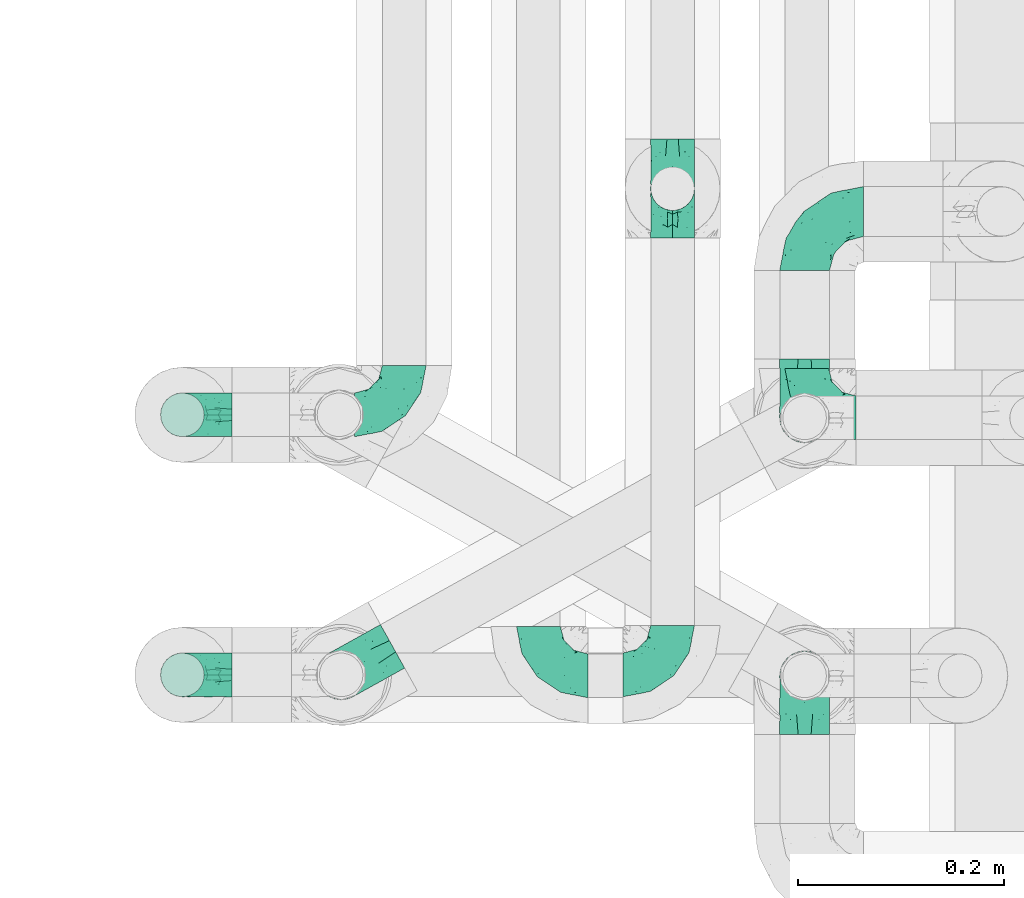
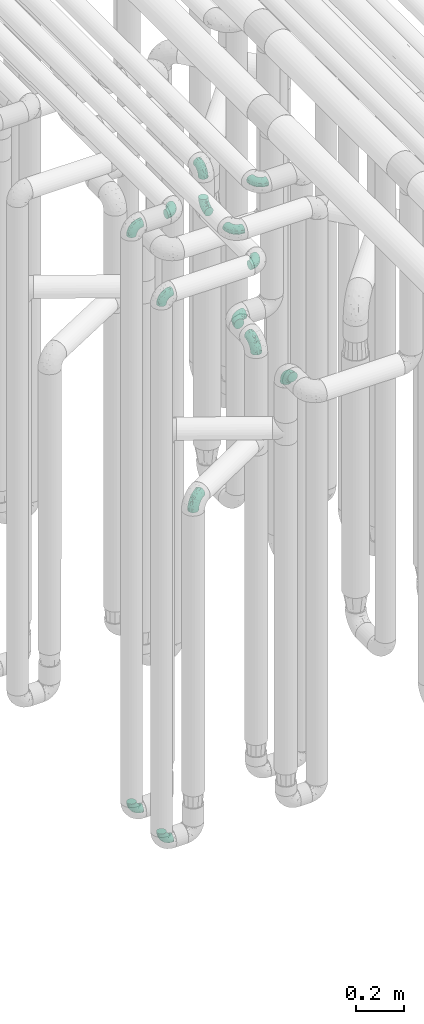
# One storey, part 598 of 827: 14 flow fittings.
"""IFC2X3 building model written with IfcOpenShell, lengths in millimetres."""

from ifc_helpers import new_model, entity, si_unit, converted_unit, derived_unit, direction, frame, origin, place, context, subcontext, project, spatial, faceted_brep, source, transform, mapped, material, type_object, type_shapes, element, save


model = new_model("IFC2X3")

# Units and contexts
model_context = context("Model", 3, precision=0.01, world=origin(), true_north=direction((6.12303176911189e-17, 1.0)))
body_context = subcontext(model_context, "Body", "Model", "MODEL_VIEW")
ifc_project = project(units=[si_unit("LENGTHUNIT", "METRE", prefix="MILLI"), si_unit("AREAUNIT", "SQUARE_METRE"), si_unit("VOLUMEUNIT", "CUBIC_METRE"), converted_unit("PLANEANGLEUNIT", "DEGREE", entity("IfcRatioMeasure", 0.0174532925199433), si_unit("PLANEANGLEUNIT", "RADIAN"), dimensions=[0, 0, 0, 0, 0, 0, 0]), si_unit("MASSUNIT", "GRAM", prefix="KILO"), derived_unit("MASSDENSITYUNIT", [(si_unit("MASSUNIT", "GRAM", prefix="KILO"), 1), (si_unit("LENGTHUNIT", "METRE"), -3)]), derived_unit("MOMENTOFINERTIAUNIT", [(si_unit("LENGTHUNIT", "METRE"), 4)]), si_unit("TIMEUNIT", "SECOND"), si_unit("FREQUENCYUNIT", "HERTZ"), si_unit("THERMODYNAMICTEMPERATUREUNIT", "DEGREE_CELSIUS"), derived_unit("THERMALTRANSMITTANCEUNIT", [(si_unit("MASSUNIT", "GRAM", prefix="KILO"), 1), (si_unit("THERMODYNAMICTEMPERATUREUNIT", "KELVIN"), -1), (si_unit("TIMEUNIT", "SECOND"), -3)]), derived_unit("VOLUMETRICFLOWRATEUNIT", [(si_unit("LENGTHUNIT", "METRE"), 3), (si_unit("TIMEUNIT", "SECOND"), -1)]), derived_unit("MASSFLOWRATEUNIT", [(si_unit("MASSUNIT", "GRAM", prefix="KILO"), 1), (si_unit("TIMEUNIT", "SECOND"), -1)]), derived_unit("ROTATIONALFREQUENCYUNIT", [(si_unit("TIMEUNIT", "SECOND"), -1)]), si_unit("ELECTRICCURRENTUNIT", "AMPERE"), si_unit("ELECTRICVOLTAGEUNIT", "VOLT"), si_unit("POWERUNIT", "WATT"), si_unit("FORCEUNIT", "NEWTON", prefix="KILO"), si_unit("ILLUMINANCEUNIT", "LUX"), si_unit("LUMINOUSFLUXUNIT", "LUMEN"), si_unit("LUMINOUSINTENSITYUNIT", "CANDELA"), derived_unit("USERDEFINED", [(si_unit("MASSUNIT", "GRAM", prefix="KILO"), -1), (si_unit("LENGTHUNIT", "METRE"), -2), (si_unit("TIMEUNIT", "SECOND"), 3), (si_unit("LUMINOUSFLUXUNIT", "LUMEN"), 1)]), derived_unit("LINEARVELOCITYUNIT", [(si_unit("LENGTHUNIT", "METRE"), 1), (si_unit("TIMEUNIT", "SECOND"), -1)]), si_unit("PRESSUREUNIT", "PASCAL"), derived_unit("USERDEFINED", [(si_unit("LENGTHUNIT", "METRE"), -2), (si_unit("MASSUNIT", "GRAM", prefix="KILO"), 1), (si_unit("TIMEUNIT", "SECOND"), -2)]), derived_unit("LINEARFORCEUNIT", [(si_unit("MASSUNIT", "GRAM", prefix="KILO"), 1), (si_unit("LENGTHUNIT", "METRE"), 1), (si_unit("TIMEUNIT", "SECOND"), -2), (si_unit("LENGTHUNIT", "METRE"), -1)]), derived_unit("PLANARFORCEUNIT", [(si_unit("MASSUNIT", "GRAM", prefix="KILO"), 1), (si_unit("LENGTHUNIT", "METRE"), 1), (si_unit("TIMEUNIT", "SECOND"), -2), (si_unit("LENGTHUNIT", "METRE"), -2)])], contexts=[model_context])

# Site, building, storey
site_placement = place(None, origin())
site = spatial("IfcSite", under=ifc_project, at=site_placement, CompositionType="ELEMENT")
building_placement = place(site_placement, origin())
building = spatial("IfcBuilding", under=site, at=building_placement, CompositionType="ELEMENT")
storey_placement = place(building_placement, frame((0.0, 0.0, 28200.0)))
storey = spatial("IfcBuildingStorey", under=building, at=storey_placement, Name="08", CompositionType="ELEMENT", Elevation=28200.0)

# Flow fittings
ifc_material = material()
pipe_fitting_type_1 = type_object("IfcPipeFittingType", Name="ADSK_1", PredefinedType="NOTDEFINED", material=ifc_material)
shared_shape_1 = source(origin(), body_context, "Body", "Brep", [
    faceted_brep([(-57.0, 12.07, -20.91), (-57.0, 6.25, -23.33), (-57.0, 0.0, -24.15), (-57.0, -6.25, -23.33), (-57.0, -12.08, -20.91), (-57.0, -17.08, -17.08), (-57.0, -20.91, -12.08), (-57.0, -23.33, -6.25), (-57.0, -24.15, 0.0), (-57.0, -23.33, 6.25), (-57.0, -20.91, 12.07), (-57.0, -17.08, 17.08), (-57.0, -12.08, 20.91), (-57.0, -6.25, 23.33), (-57.0, 0.0, 24.15), (-57.0, 6.25, 23.33), (-57.0, 12.07, 20.91), (-57.0, 17.08, 17.08), (-57.0, 20.91, 12.07), (-57.0, 23.33, 6.25), (-57.0, 24.15, 0.0), (-57.0, 23.33, -6.25), (-57.0, 20.91, -12.08), (-57.0, 17.08, -17.08), (0.0, 57.0, -24.15), (-6.25, 57.0, -23.33), (-12.07, 57.0, -20.91), (-17.08, 57.0, -17.08), (-20.91, 57.0, -12.08), (-23.33, 57.0, -6.25), (-24.15, 57.0, 0.0), (-23.33, 57.0, 6.25), (-20.91, 57.0, 12.07), (-17.08, 57.0, 17.08), (-12.07, 57.0, 20.91), (-6.25, 57.0, 23.33), (0.0, 57.0, 24.15), (6.25, 57.0, 23.33), (12.08, 57.0, 20.91), (17.08, 57.0, 17.08), (20.91, 57.0, 12.07), (23.33, 57.0, 6.25), (24.15, 57.0, 0.0), (23.33, 57.0, -6.25), (20.91, 57.0, -12.08), (17.08, 57.0, -17.08), (12.08, 57.0, -20.91), (6.25, 57.0, -23.33), (14.9, 21.14, 6.17), (13.61, 24.64, 12.48), (6.23, 8.95, 8.98), (-41.47, -21.06, 0.0), (-41.92, -18.38, 13.72), (-24.64, -13.61, 12.48), (-37.37, -13.24, 18.15), (-6.8, -4.93, 8.18), (-21.76, -15.19, 6.22), (-12.78, -9.18, 0.0), (-37.73, -20.51, 7.75), (-7.38, 7.38, 20.24), (-23.37, -4.26, 20.42), (-11.9, -3.19, 15.86), (-42.14, -8.7, 21.82), (13.24, 37.37, 18.15), (9.33, 23.53, 16.85), (4.26, 23.37, 20.42), (2.77, 10.92, 15.55), (-29.46, 0.91, 23.52), (-44.13, 20.56, 15.69), (-39.25, 26.33, 10.88), (-49.02, 22.92, 9.96), (-34.58, 23.87, 17.15), (-15.8, 6.8, 22.81), (-8.67, 20.47, 23.88), (-18.12, 12.9, 24.08), (-48.29, 14.92, 19.65), (-44.06, -2.85, 23.78), (-9.23, 48.95, 22.58), (-3.78, 42.74, 24.07), (-40.34, 4.26, 24.09), (-44.02, 26.14, 5.46), (-44.04, 9.88, 22.74), (-4.95, 16.87, 22.52), (-2.75, 1.43, 12.5), (-25.48, 40.98, 10.71), (20.51, 37.73, 7.75), (18.38, 41.92, 13.72), (8.7, 42.14, 21.82), (-25.95, -17.97, 0.0), (2.85, 44.06, 23.78), (21.06, 41.47, 0.0), (17.97, 25.95, 0.0), (-24.04, -9.27, 17.13), (-33.26, 33.26, 5.86), (-28.55, 40.57, 0.0), (-40.57, 28.55, 0.0), (-25.29, 47.19, 4.06), (-27.01, 31.1, 16.77), (-15.7, 43.95, 19.9), (-20.27, 45.22, 15.61), (-30.53, 31.98, 12.64), (-11.28, 38.33, 22.92), (-9.97, 27.88, 24.09), (-20.15, 30.26, 21.25), (-31.25, 11.75, 23.64), (-28.75, 7.23, 24.15), (-29.53, 18.06, 22.27), (-28.44, 24.21, 20.02), (-37.55, 17.7, 20.26), (-15.88, 29.25, 22.99), (-20.82, 20.82, 23.44), (-0.91, 29.46, 23.52), (-13.5, -7.67, 12.04), (1.49, 1.56, 5.16), (8.86, 10.35, 4.59), (0.38, -0.38, 0.0), (9.18, 12.78, 0.0), (-37.37, -13.24, -18.15), (8.86, 10.35, -4.59), (-45.22, 20.27, -15.61), (-43.95, 15.7, -19.9), (-38.33, 11.28, -22.92), (-48.95, 9.23, -22.58), (-47.19, 25.29, -4.06), (-33.26, 33.26, -5.86), (18.38, 41.92, -13.72), (-30.26, 20.15, -21.25), (2.85, 44.06, -23.78), (-4.26, 40.34, -24.09), (-40.98, 25.48, -10.71), (-41.92, -18.38, -13.72), (9.25, 23.5, -16.92), (4.26, 23.37, -20.42), (13.24, 37.37, -18.15), (-37.73, -20.51, -7.75), (-11.75, 31.25, -23.64), (-7.23, 28.75, -24.15), (-12.9, 18.12, -24.08), (8.7, 42.14, -21.82), (-44.06, -2.85, -23.78), (-6.8, 15.8, -22.81), (-20.47, 8.67, -23.88), (-24.64, -13.61, -12.48), (-42.74, 3.78, -24.07), (-18.06, 29.53, -22.27), (-24.21, 28.44, -20.02), (-27.88, 9.97, -24.09), (-31.1, 27.01, -16.77), (-26.14, 44.02, -5.46), (14.9, 21.14, -6.17), (20.51, 37.73, -7.75), (-9.88, 44.04, -22.74), (-20.56, 44.13, -15.69), (-21.76, -15.19, -6.22), (-13.5, -7.67, -12.04), (-24.14, -9.76, -16.74), (-11.9, -3.19, -15.86), (-14.92, 48.29, -19.65), (-23.37, -4.26, -20.42), (-0.91, 29.46, -23.52), (-26.33, 39.25, -10.88), (-23.87, 34.58, -17.15), (-42.14, -8.7, -21.82), (-22.92, 49.02, -9.96), (13.61, 24.64, -12.48), (-31.98, 30.53, -12.64), (-16.87, 4.95, -22.52), (-17.7, 37.55, -20.26), (-29.25, 15.88, -22.99), (-20.82, 20.82, -23.44), (-29.46, 0.91, -23.52), (-7.38, 7.38, -20.24), (2.77, 10.92, -15.55), (6.23, 8.95, -8.98), (-6.8, -4.93, -8.18), (-2.81, 1.41, -12.54), (1.49, 1.56, -5.16)], [[[0, 1, 2, 3, 4, 5, 6, 7, 8, 9, 10, 11, 12, 13, 14, 15, 16, 17, 18, 19, 20, 21, 22, 23]], [[24, 25, 26, 27, 28, 29, 30, 31, 32, 33, 34, 35, 36, 37, 38, 39, 40, 41, 42, 43, 44, 45, 46, 47]], [[48, 49, 50]], [[9, 8, 51]], [[52, 53, 54]], [[55, 56, 57]], [[10, 58, 52]], [[9, 58, 10]], [[59, 60, 61]], [[54, 12, 11]], [[54, 62, 12]], [[63, 39, 38]], [[64, 65, 66]], [[62, 60, 67]], [[68, 69, 70]], [[71, 69, 68]], [[72, 73, 74]], [[16, 75, 17]], [[13, 76, 14]], [[35, 77, 78]], [[14, 79, 15]], [[17, 68, 18]], [[14, 76, 79]], [[20, 19, 80]], [[70, 19, 18]], [[81, 15, 79]], [[15, 81, 16]], [[73, 72, 82]], [[66, 83, 50]], [[32, 31, 84]], [[85, 86, 49]], [[63, 87, 65]], [[56, 58, 88]], [[36, 89, 37]], [[85, 41, 40]], [[36, 35, 78]], [[90, 41, 85]], [[40, 39, 86]], [[12, 62, 13]], [[86, 85, 40]], [[48, 85, 49]], [[85, 91, 90]], [[87, 38, 37]], [[92, 60, 54]], [[80, 69, 93]], [[93, 94, 95]], [[10, 52, 11]], [[94, 96, 30]], [[97, 98, 99]], [[80, 93, 95]], [[100, 97, 84]], [[99, 98, 33]], [[101, 102, 78]], [[103, 101, 98]], [[96, 31, 30]], [[77, 98, 101]], [[77, 35, 34]], [[34, 33, 98]], [[9, 51, 58]], [[87, 63, 38]], [[104, 105, 74]], [[106, 103, 107]], [[106, 81, 104]], [[75, 68, 17]], [[108, 107, 71]], [[33, 32, 99]], [[109, 103, 110]], [[101, 109, 102]], [[89, 78, 111]], [[53, 52, 58]], [[54, 11, 52]], [[60, 62, 54]], [[88, 58, 51]], [[76, 62, 67]], [[53, 112, 92]], [[60, 59, 72]], [[39, 63, 86]], [[49, 86, 63]], [[89, 87, 37]], [[42, 41, 90]], [[111, 82, 65]], [[111, 65, 87]], [[65, 59, 66]], [[104, 81, 79]], [[75, 81, 108]], [[32, 84, 99]], [[97, 99, 84]], [[98, 97, 103]], [[106, 107, 108]], [[74, 102, 110]], [[111, 78, 102]], [[74, 110, 104]], [[74, 67, 72]], [[61, 92, 112]], [[66, 59, 61]], [[56, 53, 58]], [[66, 50, 49]], [[61, 112, 83]], [[66, 49, 64]], [[78, 89, 36]], [[87, 89, 111]], [[62, 76, 13]], [[79, 76, 67]], [[100, 93, 69]], [[96, 93, 84]], [[55, 113, 50]], [[113, 114, 50]], [[104, 79, 105]], [[106, 104, 110]], [[20, 80, 95]], [[85, 48, 91]], [[115, 114, 113]], [[116, 91, 48]], [[70, 80, 19]], [[93, 96, 94]], [[84, 31, 96]], [[103, 106, 110]], [[81, 106, 108]], [[103, 97, 107]], [[71, 107, 97]], [[71, 97, 100]], [[108, 71, 68]], [[79, 67, 105]], [[67, 74, 105]], [[115, 113, 57]], [[112, 56, 55]], [[56, 88, 57]], [[60, 72, 67]], [[82, 72, 59]], [[65, 82, 59]], [[82, 111, 73]], [[111, 102, 73]], [[102, 74, 73]], [[81, 75, 16]], [[68, 75, 108]], [[68, 70, 18]], [[80, 70, 69]], [[98, 77, 34]], [[78, 77, 101]], [[93, 100, 84]], [[71, 100, 69]], [[102, 109, 110]], [[101, 103, 109]], [[53, 92, 54]], [[61, 60, 92]], [[56, 112, 53]], [[83, 112, 55]], [[50, 83, 55]], [[61, 83, 66]], [[49, 63, 64]], [[65, 64, 63]], [[57, 113, 55]], [[114, 115, 116]], [[116, 48, 114]], [[48, 50, 114]], [[117, 5, 4]], [[116, 115, 118]], [[119, 120, 23]], [[121, 122, 120]], [[95, 123, 20]], [[0, 23, 120]], [[124, 95, 94]], [[125, 45, 44]], [[121, 120, 126]], [[24, 127, 128]], [[22, 21, 129]], [[0, 122, 1]], [[5, 117, 130]], [[131, 132, 133]], [[134, 88, 51]], [[135, 136, 137]], [[6, 5, 130]], [[46, 138, 47]], [[139, 3, 2]], [[140, 141, 137]], [[6, 134, 7]], [[134, 130, 142]], [[143, 2, 1]], [[144, 126, 145]], [[121, 146, 143]], [[147, 120, 119]], [[94, 148, 124]], [[149, 150, 91]], [[30, 29, 148]], [[151, 25, 128]], [[27, 152, 28]], [[134, 153, 88]], [[154, 155, 156]], [[27, 26, 157]], [[151, 26, 25]], [[155, 158, 156]], [[24, 47, 127]], [[1, 122, 143]], [[138, 132, 159]], [[160, 152, 161]], [[24, 128, 25]], [[46, 133, 138]], [[162, 117, 4]], [[148, 160, 124]], [[152, 160, 163]], [[154, 142, 155]], [[45, 125, 133]], [[133, 46, 45]], [[125, 164, 133]], [[51, 7, 134]], [[42, 90, 43]], [[165, 147, 129]], [[153, 134, 142]], [[43, 150, 44]], [[162, 4, 3]], [[141, 140, 166]], [[117, 162, 158]], [[163, 29, 28]], [[43, 90, 150]], [[123, 21, 20]], [[144, 151, 135]], [[157, 152, 27]], [[167, 145, 161]], [[23, 22, 119]], [[168, 126, 169]], [[121, 168, 146]], [[139, 143, 170]], [[142, 130, 117]], [[8, 7, 51]], [[134, 6, 130]], [[139, 162, 3]], [[170, 166, 158]], [[170, 158, 162]], [[158, 171, 156]], [[44, 150, 125]], [[91, 150, 90]], [[164, 125, 150]], [[132, 138, 133]], [[127, 138, 159]], [[131, 164, 172]], [[132, 171, 140]], [[135, 151, 128]], [[157, 151, 167]], [[22, 129, 119]], [[147, 119, 129]], [[120, 147, 126]], [[144, 145, 167]], [[137, 146, 169]], [[170, 143, 146]], [[137, 169, 135]], [[137, 159, 140]], [[171, 172, 156]], [[173, 174, 175]], [[156, 175, 154]], [[174, 57, 153]], [[132, 172, 171]], [[172, 164, 173]], [[143, 139, 2]], [[162, 139, 170]], [[138, 127, 47]], [[128, 127, 159]], [[165, 124, 160]], [[123, 124, 129]], [[149, 173, 164]], [[176, 174, 173]], [[135, 128, 136]], [[144, 135, 169]], [[150, 149, 164]], [[176, 118, 115]], [[149, 91, 116]], [[30, 148, 94]], [[163, 148, 29]], [[124, 123, 95]], [[129, 21, 123]], [[126, 144, 169]], [[151, 144, 167]], [[126, 147, 145]], [[161, 145, 147]], [[161, 147, 165]], [[167, 161, 152]], [[128, 159, 136]], [[159, 137, 136]], [[154, 153, 142]], [[132, 140, 159]], [[174, 176, 57]], [[57, 88, 153]], [[166, 140, 171]], [[158, 166, 171]], [[166, 170, 141]], [[170, 146, 141]], [[146, 137, 141]], [[151, 157, 26]], [[152, 157, 167]], [[152, 163, 28]], [[148, 163, 160]], [[120, 122, 0]], [[143, 122, 121]], [[124, 165, 129]], [[161, 165, 160]], [[146, 168, 169]], [[121, 126, 168]], [[142, 117, 155]], [[158, 155, 117]], [[175, 156, 172]], [[153, 154, 174]], [[173, 175, 172]], [[174, 154, 175]], [[164, 131, 133]], [[172, 132, 131]], [[176, 173, 118]], [[57, 176, 115]], [[173, 149, 118]], [[149, 116, 118]]]),
])
type_shapes(pipe_fitting_type_1, [shared_shape_1])
for number, where, z_axis, x_axis, name in (
    (1, (35728.05, 10606.2, 2600.0), (-1.0, 0.0, 0.0), (0.0, 0.0, 1.0), "ADSK_1"),
    (2, (35728.05, 10806.2, 2600.0), (0.0, 0.0, 1.0), (-1.0, 0.0, 0.0), "ADSK_1"),
    (3, (35728.05, 10356.17, 2600.0), (1.0, 0.0, 0.0), (0.0, 0.0, 1.0), "ADSK_1"),
    (4, (35278.87, 10357.09, 2100.0), (0.486104408033655, -0.873900740639491, 0.0), (-0.873900740639491, -0.486104408033655, 0.0), "ADSK_1"),
):
    element("IfcFlowFitting", number, at=place(storey_placement, frame(where, z_axis=z_axis, x_axis=x_axis)), inside=storey, type_object=pipe_fitting_type_1, material=ifc_material, Name=name, ObjectType="ADSK_1", context=body_context, shape_type="MappedRepresentation", body=[
        mapped(shared_shape_1, transform((0.0, 0.0, 0.0), scale=1.0)),
    ])
pipe_fitting_type_2 = type_object("IfcPipeFittingType", Name="ADSK_1", PredefinedType="NOTDEFINED", material=ifc_material)
shared_shape_2 = source(origin(), body_context, "Body", "Brep", [
    faceted_brep([(-48.0, 10.6, -18.36), (-48.0, 5.49, -20.48), (-48.0, 0.0, -21.2), (-48.0, -5.49, -20.48), (-48.0, -10.6, -18.36), (-48.0, -14.99, -14.99), (-48.0, -18.36, -10.6), (-48.0, -20.48, -5.49), (-48.0, -21.2, 0.0), (-48.0, -20.48, 5.49), (-48.0, -18.36, 10.6), (-48.0, -14.99, 14.99), (-48.0, -10.6, 18.36), (-48.0, -5.49, 20.48), (-48.0, 0.0, 21.2), (-48.0, 5.49, 20.48), (-48.0, 10.6, 18.36), (-48.0, 14.99, 14.99), (-48.0, 18.36, 10.6), (-48.0, 20.48, 5.49), (-48.0, 21.2, 0.0), (-48.0, 20.48, -5.49), (-48.0, 18.36, -10.6), (-48.0, 14.99, -14.99), (0.0, 48.0, -21.2), (-5.49, 48.0, -20.48), (-10.6, 48.0, -18.36), (-14.99, 48.0, -14.99), (-18.36, 48.0, -10.6), (-20.48, 48.0, -5.49), (-21.2, 48.0, 0.0), (-20.48, 48.0, 5.49), (-18.36, 48.0, 10.6), (-14.99, 48.0, 14.99), (-10.6, 48.0, 18.36), (-5.49, 48.0, 20.48), (0.0, 48.0, 21.2), (5.49, 48.0, 20.48), (10.6, 48.0, 18.36), (14.99, 48.0, 14.99), (18.36, 48.0, 10.6), (20.48, 48.0, 5.49), (21.2, 48.0, 0.0), (20.48, 48.0, -5.49), (18.36, 48.0, -10.6), (14.99, 48.0, -14.99), (10.6, 48.0, -18.36), (5.49, 48.0, -20.48), (-35.25, -16.22, 12.01), (-34.76, -18.57, 0.0), (-20.87, -12.37, 10.9), (-31.49, -11.78, 15.9), (-37.0, -2.58, 20.86), (-33.89, 3.62, 21.15), (-31.81, -18.14, 6.76), (-5.78, 5.78, 17.67), (-19.42, -4.1, 17.86), (-9.6, -3.39, 13.73), (-35.44, -7.73, 19.13), (11.78, 31.49, 15.9), (-5.93, -5.46, 6.95), (-18.45, -13.78, 5.46), (-10.29, -8.43, 0.0), (-24.6, 0.55, 20.62), (-37.28, 17.94, 13.81), (-33.38, 22.85, 9.59), (-41.46, 20.06, 8.75), (-29.51, 20.45, 15.16), (-15.04, 10.79, 21.13), (-7.08, 16.98, 20.93), (-8.39, 23.51, 21.15), (-40.86, 13.03, 17.26), (-8.05, 41.26, 19.83), (-3.21, 35.97, 21.14), (8.53, 19.66, 14.74), (4.1, 19.42, 17.86), (-37.72, 22.66, 4.78), (-37.07, 8.58, 19.98), (-13.0, 5.43, 19.97), (-3.78, 13.93, 19.7), (3.02, 8.69, 13.43), (-2.27, -0.05, 10.65), (6.22, 6.99, 7.09), (-22.25, 34.6, 9.45), (18.14, 31.81, 6.76), (16.22, 35.25, 12.01), (12.37, 20.87, 10.9), (7.73, 35.44, 19.13), (-21.52, -15.93, 0.0), (2.58, 37.0, 20.86), (18.57, 34.76, 0.0), (13.78, 18.45, 5.46), (15.93, 21.52, 0.0), (-20.03, -8.54, 14.9), (-28.6, 28.6, 5.16), (-24.79, 34.6, 0.0), (-34.6, 24.79, 0.0), (-22.81, 37.41, 4.68), (-23.36, 26.33, 14.79), (-13.68, 37.05, 17.49), (-17.72, 38.12, 13.73), (-26.25, 27.3, 11.24), (-9.71, 32.34, 20.14), (-17.26, 25.6, 18.71), (-26.33, 9.99, 20.77), (-24.06, 6.05, 21.2), (-25.02, 15.46, 19.56), (-24.3, 20.72, 17.57), (-31.95, 15.23, 17.8), (-13.53, 24.7, 20.21), (-17.6, 17.6, 20.6), (-0.55, 24.6, 20.62), (-11.41, -7.48, 10.43), (0.93, -0.93, 0.0), (8.43, 10.29, 0.0), (-11.41, -7.48, -10.43), (-20.1, -8.84, -14.66), (-9.6, -3.39, -13.73), (7.73, 35.44, -19.13), (4.1, 19.42, -17.86), (-0.55, 24.6, -20.62), (-38.12, 17.72, -13.73), (-37.05, 13.68, -17.49), (-32.34, 9.71, -20.14), (-41.26, 8.05, -19.83), (-37.41, 22.81, -4.68), (-23.51, 8.39, -21.15), (-35.97, 3.21, -21.14), (-28.6, 28.6, -5.16), (-31.81, -18.14, -6.76), (-18.45, -13.78, -5.46), (-25.6, 17.26, -18.71), (-19.42, -4.1, -17.86), (-17.94, 37.28, -13.81), (-22.85, 33.38, -9.59), (-20.06, 41.46, -8.75), (-31.49, -11.78, -15.9), (-35.25, -16.22, -12.01), (8.53, 19.66, -14.74), (11.78, 31.49, -15.9), (-9.99, 26.33, -20.77), (-6.05, 24.06, -21.2), (-10.79, 15.04, -21.13), (-37.0, -2.58, -20.86), (-16.98, 7.08, -20.93), (-5.43, 13.0, -19.97), (-13.93, 3.78, -19.7), (-20.87, -12.37, -10.9), (-26.33, 23.36, -14.79), (-22.66, 37.72, -4.78), (13.78, 18.45, -5.46), (18.14, 31.81, -6.76), (-15.46, 25.02, -19.56), (-20.72, 24.3, -17.57), (16.22, 35.25, -12.01), (-13.03, 40.86, -17.26), (-8.58, 37.07, -19.98), (2.58, 37.0, -20.86), (-3.62, 33.89, -21.15), (-34.6, 22.25, -9.45), (6.22, 6.99, -7.09), (-20.45, 29.51, -15.16), (-35.44, -7.73, -19.13), (12.37, 20.87, -10.9), (-27.3, 26.25, -11.24), (-15.23, 31.95, -17.8), (-24.7, 13.53, -20.21), (-24.6, 0.55, -20.62), (-5.78, 5.78, -17.67), (-17.6, 17.6, -20.6), (3.02, 8.69, -13.43), (-5.93, -5.46, -6.95), (-2.27, -0.05, -10.65)], [[[0, 1, 2, 3, 4, 5, 6, 7, 8, 9, 10, 11, 12, 13, 14, 15, 16, 17, 18, 19, 20, 21, 22, 23]], [[24, 25, 26, 27, 28, 29, 30, 31, 32, 33, 34, 35, 36, 37, 38, 39, 40, 41, 42, 43, 44, 45, 46, 47]], [[10, 48, 11]], [[9, 8, 49]], [[48, 50, 51]], [[14, 52, 53]], [[10, 54, 48]], [[9, 54, 10]], [[55, 56, 57]], [[51, 12, 11]], [[51, 58, 12]], [[59, 39, 38]], [[60, 61, 62]], [[58, 56, 63]], [[64, 65, 66]], [[67, 65, 64]], [[68, 69, 70]], [[16, 71, 17]], [[13, 52, 14]], [[35, 72, 73]], [[14, 53, 15]], [[17, 64, 18]], [[74, 59, 75]], [[20, 19, 76]], [[66, 19, 18]], [[77, 15, 53]], [[15, 77, 16]], [[69, 78, 79]], [[80, 81, 82]], [[32, 31, 83]], [[84, 85, 86]], [[59, 87, 75]], [[61, 54, 88]], [[36, 89, 37]], [[84, 41, 40]], [[36, 35, 73]], [[90, 41, 84]], [[40, 39, 85]], [[12, 58, 13]], [[85, 84, 40]], [[91, 84, 86]], [[84, 92, 90]], [[87, 38, 37]], [[93, 56, 51]], [[65, 94, 76]], [[94, 95, 96]], [[84, 91, 92]], [[95, 97, 30]], [[98, 99, 100]], [[76, 94, 96]], [[101, 98, 83]], [[100, 99, 33]], [[102, 70, 73]], [[103, 102, 99]], [[94, 97, 95]], [[72, 99, 102]], [[72, 35, 34]], [[34, 33, 99]], [[9, 49, 54]], [[87, 59, 38]], [[104, 105, 68]], [[106, 103, 107]], [[106, 77, 104]], [[71, 64, 17]], [[108, 107, 67]], [[33, 32, 100]], [[109, 103, 110]], [[102, 109, 70]], [[89, 73, 111]], [[50, 48, 54]], [[51, 11, 48]], [[56, 58, 51]], [[88, 54, 49]], [[52, 58, 63]], [[50, 112, 93]], [[56, 55, 78]], [[39, 59, 85]], [[86, 85, 59]], [[89, 87, 37]], [[42, 41, 90]], [[111, 79, 75]], [[111, 75, 87]], [[75, 55, 80]], [[104, 77, 53]], [[71, 77, 108]], [[32, 83, 100]], [[98, 100, 83]], [[99, 98, 103]], [[106, 107, 108]], [[68, 70, 110]], [[111, 73, 70]], [[68, 110, 104]], [[68, 63, 78]], [[57, 93, 112]], [[80, 55, 57]], [[61, 50, 54]], [[80, 82, 86]], [[81, 57, 112]], [[74, 86, 59]], [[60, 113, 82]], [[82, 114, 91]], [[101, 94, 65]], [[97, 94, 83]], [[73, 89, 36]], [[87, 89, 111]], [[58, 52, 13]], [[53, 52, 63]], [[104, 53, 105]], [[106, 104, 110]], [[20, 76, 96]], [[76, 19, 66]], [[103, 106, 110]], [[77, 106, 108]], [[103, 98, 107]], [[67, 107, 98]], [[67, 98, 101]], [[108, 67, 64]], [[53, 63, 105]], [[63, 68, 105]], [[83, 31, 97]], [[30, 97, 31]], [[62, 113, 60]], [[112, 61, 60]], [[61, 88, 62]], [[86, 82, 91]], [[56, 78, 63]], [[114, 82, 113]], [[114, 92, 91]], [[79, 78, 55]], [[75, 79, 55]], [[69, 79, 111]], [[70, 69, 111]], [[78, 69, 68]], [[77, 71, 16]], [[64, 71, 108]], [[64, 66, 18]], [[76, 66, 65]], [[99, 72, 34]], [[73, 72, 102]], [[94, 101, 83]], [[67, 101, 65]], [[75, 80, 74]], [[80, 86, 74]], [[70, 109, 110]], [[102, 103, 109]], [[50, 93, 51]], [[57, 56, 93]], [[61, 112, 50]], [[81, 112, 60]], [[82, 81, 60]], [[80, 57, 81]], [[115, 116, 117]], [[118, 119, 120]], [[121, 122, 23]], [[123, 124, 122]], [[96, 125, 20]], [[123, 126, 127]], [[128, 96, 95]], [[129, 130, 88]], [[123, 122, 131]], [[116, 132, 117]], [[133, 134, 135]], [[0, 124, 1]], [[5, 136, 137]], [[138, 119, 139]], [[129, 88, 49]], [[140, 141, 142]], [[6, 5, 137]], [[46, 118, 47]], [[143, 3, 2]], [[144, 145, 146]], [[6, 129, 7]], [[129, 137, 147]], [[127, 2, 1]], [[148, 122, 121]], [[128, 125, 96]], [[134, 128, 149]], [[95, 149, 128]], [[150, 151, 92]], [[30, 29, 149]], [[152, 131, 153]], [[27, 133, 28]], [[154, 45, 44]], [[136, 5, 4]], [[27, 26, 155]], [[156, 26, 25]], [[24, 157, 158]], [[24, 47, 157]], [[22, 21, 159]], [[160, 150, 114]], [[134, 133, 161]], [[142, 144, 126]], [[46, 139, 118]], [[162, 136, 4]], [[156, 25, 158]], [[1, 124, 127]], [[115, 147, 116]], [[45, 154, 139]], [[139, 46, 45]], [[154, 163, 139]], [[162, 4, 3]], [[42, 90, 43]], [[130, 129, 147]], [[49, 7, 129]], [[43, 151, 44]], [[0, 23, 122]], [[24, 158, 25]], [[136, 162, 132]], [[135, 29, 28]], [[43, 90, 151]], [[164, 148, 159]], [[152, 156, 140]], [[155, 133, 27]], [[165, 153, 161]], [[23, 22, 121]], [[123, 131, 166]], [[123, 166, 126]], [[143, 127, 167]], [[147, 137, 136]], [[8, 7, 49]], [[129, 6, 137]], [[143, 162, 3]], [[167, 146, 132]], [[167, 132, 162]], [[132, 168, 117]], [[44, 151, 154]], [[92, 151, 90]], [[163, 154, 151]], [[119, 118, 139]], [[157, 118, 120]], [[138, 139, 163]], [[119, 168, 145]], [[140, 156, 158]], [[155, 156, 165]], [[22, 159, 121]], [[148, 121, 159]], [[122, 148, 131]], [[152, 153, 165]], [[142, 126, 169]], [[167, 127, 126]], [[142, 169, 140]], [[142, 120, 145]], [[168, 170, 117]], [[160, 171, 172]], [[115, 172, 171]], [[171, 62, 130]], [[119, 170, 168]], [[170, 163, 160]], [[150, 163, 151]], [[113, 171, 160]], [[164, 128, 134]], [[125, 128, 159]], [[127, 143, 2]], [[162, 143, 167]], [[118, 157, 47]], [[158, 157, 120]], [[140, 158, 141]], [[152, 140, 169]], [[30, 149, 95]], [[149, 29, 135]], [[131, 152, 169]], [[156, 152, 165]], [[131, 148, 153]], [[161, 153, 148]], [[161, 148, 164]], [[165, 161, 133]], [[158, 120, 141]], [[120, 142, 141]], [[159, 21, 125]], [[20, 125, 21]], [[115, 130, 147]], [[114, 113, 160]], [[62, 171, 113]], [[62, 88, 130]], [[160, 163, 150]], [[150, 92, 114]], [[119, 145, 120]], [[146, 145, 168]], [[132, 146, 168]], [[144, 146, 167]], [[126, 144, 167]], [[145, 144, 142]], [[156, 155, 26]], [[133, 155, 165]], [[133, 135, 28]], [[149, 135, 134]], [[122, 124, 0]], [[127, 124, 123]], [[128, 164, 159]], [[161, 164, 134]], [[163, 170, 138]], [[170, 119, 138]], [[131, 169, 166]], [[126, 166, 169]], [[147, 136, 116]], [[132, 116, 136]], [[172, 115, 117]], [[130, 115, 171]], [[117, 170, 172]], [[160, 172, 170]]]),
])
type_shapes(pipe_fitting_type_2, [shared_shape_2])
for number, where, z_axis, x_axis, name in (
    (5, (35125.03, 10609.14, 400.0), (0.0, 1.0, 0.0), (-1.0, 0.0, 0.0), "ADSK_1"),
    (6, (35125.03, 10609.14, 3400.0), (0.0, 1.0, 0.0), (0.0, 0.0, 1.0), "ADSK_1"),
):
    element("IfcFlowFitting", number, at=place(storey_placement, frame(where, z_axis=z_axis, x_axis=x_axis)), inside=storey, type_object=pipe_fitting_type_2, material=ifc_material, Name=name, ObjectType="ADSK_1", context=body_context, shape_type="MappedRepresentation", body=[
        mapped(shared_shape_2, transform((0.0, 0.0, 0.0), scale=1.0)),
    ])
flow_fitting_1_placement = place(storey_placement, frame((35340.03, 10609.14, 3400.0)))
element("IfcFlowFitting", 7, at=flow_fitting_1_placement, inside=storey, type_object=pipe_fitting_type_2, material=ifc_material, Name="ADSK_1", ObjectType="ADSK_1", context=body_context, shape_type="MappedRepresentation", body=[
    mapped(shared_shape_2, transform((0.0, 0.0, 0.0), scale=1.0)),
])
for number, where, z_axis, x_axis, name in (
    (8, (35125.03, 10357.08, 400.0), (0.0, 1.0, 0.0), (-1.0, 0.0, 0.0), "ADSK_1"),
    (9, (35125.03, 10357.08, 3200.0), (0.0, 1.0, 0.0), (0.0, 0.0, 1.0), "ADSK_1"),
    (10, (35600.09, 10828.38, 3400.0), (1.0, 0.0, 0.0), (0.0, -1.0, 0.0), "ADSK_1"),
):
    element("IfcFlowFitting", number, at=place(storey_placement, frame(where, z_axis=z_axis, x_axis=x_axis)), inside=storey, type_object=pipe_fitting_type_2, material=ifc_material, Name=name, ObjectType="ADSK_1", context=body_context, shape_type="MappedRepresentation", body=[
        mapped(shared_shape_2, transform((0.0, 0.0, 0.0), scale=1.0)),
    ])
flow_fitting_2_placement = place(storey_placement, frame((35600.09, 10357.08, 3200.0)))
element("IfcFlowFitting", 11, at=flow_fitting_2_placement, inside=storey, type_object=pipe_fitting_type_2, material=ifc_material, Name="ADSK_1", ObjectType="ADSK_1", context=body_context, shape_type="MappedRepresentation", body=[
    mapped(shared_shape_2, transform((0.0, 0.0, 0.0), scale=1.0)),
])
for number, where, z_axis, x_axis, name in (
    (12, (35600.09, 10828.38, 3200.0), (-1.0, 0.0, 0.0), (0.0, 0.0, -1.0), "ADSK_1"),
    (13, (35470.03, 10356.17, 3400.0), (0.0, 0.0, 1.0), (0.0, -1.0, 0.0), "ADSK_1"),
    (14, (35730.03, 10606.2, 3400.0), (0.0, 0.0, 1.0), (0.0, -1.0, 0.0), "ADSK_1"),
):
    element("IfcFlowFitting", number, at=place(storey_placement, frame(where, z_axis=z_axis, x_axis=x_axis)), inside=storey, type_object=pipe_fitting_type_2, material=ifc_material, Name=name, ObjectType="ADSK_1", context=body_context, shape_type="MappedRepresentation", body=[
        mapped(shared_shape_2, transform((0.0, 0.0, 0.0), scale=1.0)),
    ])

save(model, "model.ifc")
